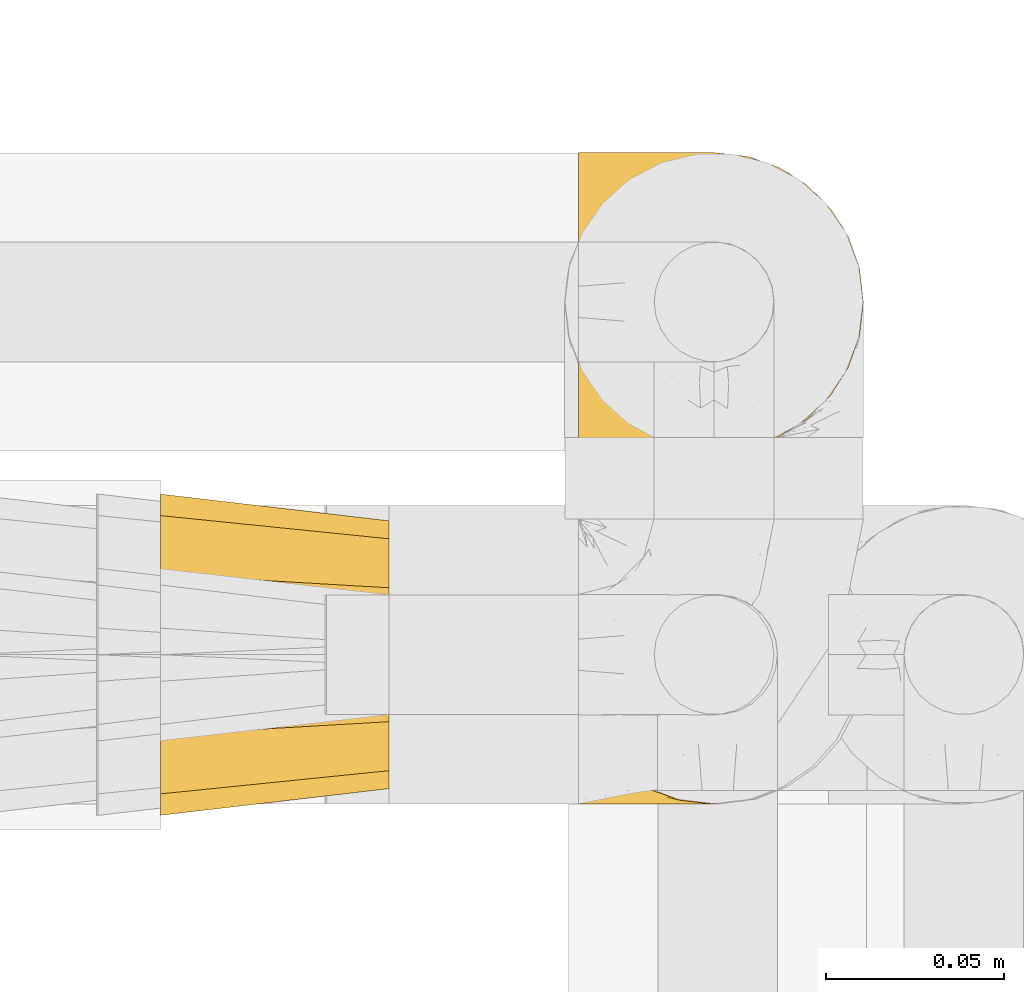
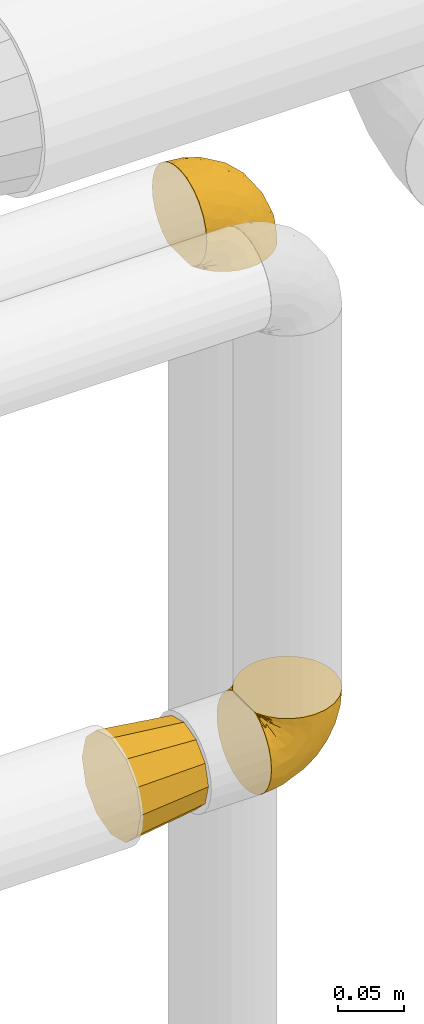
# One storey, part 455 of 827: 3 coverings.
"""IFC2X3 building model written with IfcOpenShell, lengths in millimetres."""

from ifc_helpers import new_model, entity, si_unit, converted_unit, derived_unit, direction, frame, origin, place, context, subcontext, project, spatial, faceted_brep, element, save


model = new_model("IFC2X3")

# Units and contexts
model_context = context("Model", 3, precision=0.01, world=origin(), true_north=direction((6.12303176911189e-17, 1.0)))
body_context = subcontext(model_context, "Body", "Model", "MODEL_VIEW")
ifc_project = project(units=[si_unit("LENGTHUNIT", "METRE", prefix="MILLI"), si_unit("AREAUNIT", "SQUARE_METRE"), si_unit("VOLUMEUNIT", "CUBIC_METRE"), converted_unit("PLANEANGLEUNIT", "DEGREE", entity("IfcRatioMeasure", 0.0174532925199433), si_unit("PLANEANGLEUNIT", "RADIAN"), dimensions=[0, 0, 0, 0, 0, 0, 0]), si_unit("MASSUNIT", "GRAM", prefix="KILO"), derived_unit("MASSDENSITYUNIT", [(si_unit("MASSUNIT", "GRAM", prefix="KILO"), 1), (si_unit("LENGTHUNIT", "METRE"), -3)]), derived_unit("MOMENTOFINERTIAUNIT", [(si_unit("LENGTHUNIT", "METRE"), 4)]), si_unit("TIMEUNIT", "SECOND"), si_unit("FREQUENCYUNIT", "HERTZ"), si_unit("THERMODYNAMICTEMPERATUREUNIT", "DEGREE_CELSIUS"), derived_unit("THERMALTRANSMITTANCEUNIT", [(si_unit("MASSUNIT", "GRAM", prefix="KILO"), 1), (si_unit("THERMODYNAMICTEMPERATUREUNIT", "KELVIN"), -1), (si_unit("TIMEUNIT", "SECOND"), -3)]), derived_unit("VOLUMETRICFLOWRATEUNIT", [(si_unit("LENGTHUNIT", "METRE"), 3), (si_unit("TIMEUNIT", "SECOND"), -1)]), derived_unit("MASSFLOWRATEUNIT", [(si_unit("MASSUNIT", "GRAM", prefix="KILO"), 1), (si_unit("TIMEUNIT", "SECOND"), -1)]), derived_unit("ROTATIONALFREQUENCYUNIT", [(si_unit("TIMEUNIT", "SECOND"), -1)]), si_unit("ELECTRICCURRENTUNIT", "AMPERE"), si_unit("ELECTRICVOLTAGEUNIT", "VOLT"), si_unit("POWERUNIT", "WATT"), si_unit("FORCEUNIT", "NEWTON", prefix="KILO"), si_unit("ILLUMINANCEUNIT", "LUX"), si_unit("LUMINOUSFLUXUNIT", "LUMEN"), si_unit("LUMINOUSINTENSITYUNIT", "CANDELA"), derived_unit("USERDEFINED", [(si_unit("MASSUNIT", "GRAM", prefix="KILO"), -1), (si_unit("LENGTHUNIT", "METRE"), -2), (si_unit("TIMEUNIT", "SECOND"), 3), (si_unit("LUMINOUSFLUXUNIT", "LUMEN"), 1)]), derived_unit("LINEARVELOCITYUNIT", [(si_unit("LENGTHUNIT", "METRE"), 1), (si_unit("TIMEUNIT", "SECOND"), -1)]), si_unit("PRESSUREUNIT", "PASCAL"), derived_unit("USERDEFINED", [(si_unit("LENGTHUNIT", "METRE"), -2), (si_unit("MASSUNIT", "GRAM", prefix="KILO"), 1), (si_unit("TIMEUNIT", "SECOND"), -2)]), derived_unit("LINEARFORCEUNIT", [(si_unit("MASSUNIT", "GRAM", prefix="KILO"), 1), (si_unit("LENGTHUNIT", "METRE"), 1), (si_unit("TIMEUNIT", "SECOND"), -2), (si_unit("LENGTHUNIT", "METRE"), -1)]), derived_unit("PLANARFORCEUNIT", [(si_unit("MASSUNIT", "GRAM", prefix="KILO"), 1), (si_unit("LENGTHUNIT", "METRE"), 1), (si_unit("TIMEUNIT", "SECOND"), -2), (si_unit("LENGTHUNIT", "METRE"), -2)])], contexts=[model_context])

# Site, building, storey
site_placement = place(None, origin())
site = spatial("IfcSite", under=ifc_project, at=site_placement, CompositionType="ELEMENT")
building_placement = place(site_placement, origin())
building = spatial("IfcBuilding", under=site, at=building_placement, CompositionType="ELEMENT")
storey_placement = place(building_placement, frame((0.0, 0.0, 28200.0)))
storey = spatial("IfcBuildingStorey", under=building, at=storey_placement, Name="08", CompositionType="ELEMENT", Elevation=28200.0)

# Coverings
covering_1_placement = place(storey_placement, frame((56523.63, 17456.55, 2524.05)))
element("IfcCovering", 1, at=covering_1_placement, inside=storey, Name=":ADSK_", ObjectType=":ADSK_", PredefinedType="INSULATION", context=body_context, shape_type="Brep", body=[
    faceted_brep([(1.6, 81.15, 25.28), (1.6, 76.16, 17.35), (1.6, 69.53, 10.72), (1.6, 61.6, 5.74), (1.6, 52.75, 2.64), (1.6, 43.45, 1.6), (1.6, 34.13, 2.65), (1.6, 25.28, 5.74), (1.6, 17.35, 10.73), (1.6, 10.72, 17.36), (1.6, 5.74, 25.29), (1.6, 2.64, 34.14), (1.6, 1.6, 43.45), (1.6, 2.66, 52.82), (1.6, 5.79, 61.71), (1.6, 10.83, 69.67), (1.6, 17.53, 76.31), (1.6, 25.53, 81.27), (1.6, 26.45, 81.27), (1.6, 27.37, 81.27), (1.6, 28.17, 81.27), (1.6, 29.49, 81.27), (1.6, 30.81, 81.27), (1.6, 32.13, 81.27), (1.6, 33.45, 81.27), (1.6, 34.78, 81.27), (1.6, 36.1, 81.27), (1.6, 37.42, 81.27), (1.6, 38.74, 81.27), (1.6, 40.06, 81.27), (1.6, 41.38, 81.27), (1.6, 42.7, 81.27), (1.6, 44.02, 81.27), (1.6, 45.34, 81.27), (1.6, 46.66, 81.27), (1.6, 47.58, 81.27), (1.6, 48.5, 81.27), (1.6, 49.41, 81.27), (1.6, 50.33, 81.27), (1.6, 51.25, 81.27), (1.6, 52.17, 81.27), (1.6, 53.09, 81.27), (1.6, 54.01, 81.27), (1.6, 54.93, 81.27), (1.6, 55.85, 81.27), (1.6, 56.76, 81.27), (1.6, 57.68, 81.27), (1.6, 58.6, 81.27), (1.6, 59.52, 81.27), (1.6, 60.44, 81.27), (1.6, 61.36, 81.27), (1.6, 69.37, 76.3), (1.6, 76.07, 69.66), (1.6, 81.11, 61.69), (1.6, 84.24, 52.8), (1.6, 85.3, 43.45), (1.6, 84.24, 34.13), (6.74, 17.52, 81.45), (13.37, 10.83, 81.45), (21.34, 5.79, 81.45), (30.23, 2.66, 81.45), (39.6, 1.6, 81.45), (50.43, 3.02, 81.45), (60.52, 7.2, 81.45), (69.19, 13.85, 81.45), (75.84, 22.52, 81.45), (80.02, 32.61, 81.45), (81.45, 43.45, 81.45), (80.02, 54.28, 81.45), (75.84, 64.37, 81.45), (69.19, 73.04, 81.45), (60.52, 79.69, 81.45), (50.43, 83.87, 81.45), (39.6, 85.3, 81.45), (30.23, 84.23, 81.45), (21.34, 81.1, 81.45), (13.37, 76.06, 81.45), (6.74, 69.37, 81.45), (1.77, 61.36, 81.45), (1.77, 60.44, 81.45), (1.77, 59.12, 81.45), (1.77, 58.0, 81.45), (1.77, 56.88, 81.45), (1.77, 55.76, 81.45), (1.77, 54.64, 81.45), (1.77, 53.52, 81.45), (1.77, 52.4, 81.45), (1.77, 51.28, 81.45), (1.77, 50.16, 81.45), (1.77, 49.04, 81.45), (1.77, 47.92, 81.45), (1.77, 46.8, 81.45), (1.77, 45.68, 81.45), (1.77, 44.56, 81.45), (1.77, 43.45, 81.45), (1.77, 42.12, 81.45), (1.77, 40.8, 81.45), (1.77, 39.48, 81.45), (1.77, 38.16, 81.45), (1.77, 36.84, 81.45), (1.77, 35.52, 81.45), (1.77, 34.2, 81.45), (1.77, 32.88, 81.45), (1.77, 31.96, 81.45), (1.77, 31.05, 81.45), (1.77, 30.13, 81.45), (1.77, 29.21, 81.45), (1.77, 28.29, 81.45), (1.77, 27.37, 81.45), (1.77, 26.45, 81.45), (1.77, 25.53, 81.45), (1.73, 54.08, 81.33), (1.72, 55.16, 81.32), (1.73, 36.18, 81.33), (1.72, 35.13, 81.32), (1.73, 44.01, 81.33), (1.73, 45.08, 81.32), (1.72, 61.36, 81.32), (1.72, 59.98, 81.32), (1.72, 46.18, 81.32), (1.72, 26.74, 81.32), (1.72, 47.36, 81.32), (1.73, 29.67, 81.32), (1.74, 28.72, 81.34), (1.72, 39.77, 81.32), (1.71, 52.96, 81.31), (1.73, 51.84, 81.33), (1.71, 40.8, 81.31), (1.72, 41.87, 81.32), (1.73, 42.94, 81.33), (1.72, 27.77, 81.32), (1.73, 48.4, 81.33), (1.72, 37.21, 81.32), (1.73, 33.54, 81.33), (1.72, 32.49, 81.32), (1.72, 30.69, 81.32), (1.72, 50.69, 81.32), (1.71, 49.6, 81.31), (1.72, 56.32, 81.32), (1.73, 57.44, 81.33), (1.71, 58.88, 81.31), (1.72, 25.53, 81.32), (1.68, 61.36, 81.3), (1.64, 61.36, 81.29), (1.64, 25.53, 81.29), (1.68, 25.53, 81.3), (1.75, 61.36, 81.4), (1.74, 61.36, 81.36), (1.74, 25.53, 81.36), (1.75, 25.53, 81.4), (1.7, 31.59, 81.3), (1.73, 38.71, 81.33), (24.54, 3.97, 74.06), (11.1, 1.6, 45.99), (8.47, 3.97, 58.35), (9.11, 8.09, 67.76), (4.86, 8.09, 66.18), (5.0, 16.43, 76.46), (6.81, 15.73, 77.33), (37.05, 1.6, 71.95), (9.03, 10.79, 72.25), (9.47, 13.99, 78.91), (16.39, 8.08, 76.42), (3.95, 14.0, 73.52), (9.9, 12.83, 76.9), (22.7, 3.18, 65.25), (34.5, 1.6, 62.45), (37.68, 1.6, 74.31), (15.82, 3.28, 59.38), (20.6, 1.6, 48.54), (14.37, 6.28, 67.72), (27.55, 1.6, 55.49), (5.2, 19.06, 79.73), (14.88, 8.08, 73.23), (8.73, 1.6, 45.36), (44.27, 32.11, 15.81), (20.94, 29.62, 6.4), (32.15, 43.45, 7.67), (46.13, 2.45, 68.46), (42.67, 2.5, 59.33), (55.18, 9.73, 48.7), (67.27, 17.97, 53.94), (62.91, 10.24, 65.02), (51.5, 4.78, 60.77), (54.79, 4.78, 72.07), (25.78, 8.01, 26.25), (13.05, 8.01, 22.29), (18.46, 13.85, 16.0), (32.4, 2.42, 46.93), (31.07, 21.17, 14.19), (77.32, 35.73, 58.46), (75.62, 27.43, 61.51), (16.9, 43.45, 4.64), (71.69, 17.97, 68.93), (61.4, 35.71, 29.62), (54.47, 29.47, 24.85), (27.66, 3.41, 38.55), (14.53, 3.94, 31.27), (15.56, 21.17, 9.35), (42.26, 7.92, 37.15), (41.51, 4.25, 47.07), (36.93, 11.75, 26.49), (42.72, 18.31, 23.01), (44.68, 24.94, 19.4), (71.2, 28.78, 48.06), (70.48, 35.82, 42.46), (75.37, 43.45, 50.89), (63.65, 28.38, 35.78), (58.06, 43.45, 24.98), (45.11, 43.45, 16.33), (78.4, 43.45, 66.14), (54.95, 21.21, 30.96), (59.31, 16.48, 41.83), (49.01, 13.85, 33.28), (66.71, 43.45, 37.94), (53.75, 82.11, 67.39), (77.27, 51.41, 58.47), (61.6, 57.45, 32.5), (44.24, 54.78, 15.79), (18.46, 73.03, 15.99), (15.55, 65.7, 9.34), (60.14, 76.65, 56.91), (70.5, 68.92, 63.5), (63.0, 68.01, 44.08), (25.78, 78.88, 26.24), (13.05, 78.88, 22.27), (14.53, 82.94, 31.26), (48.5, 64.44, 23.95), (44.23, 84.49, 63.79), (34.5, 85.3, 62.45), (37.05, 85.3, 71.95), (8.73, 85.3, 45.36), (77.68, 57.84, 67.83), (64.08, 76.65, 70.28), (70.25, 51.19, 42.11), (20.93, 57.26, 6.39), (49.9, 78.14, 43.54), (49.6, 82.35, 58.03), (31.06, 65.7, 14.18), (39.62, 84.61, 56.34), (34.42, 84.36, 48.09), (20.6, 85.3, 48.54), (27.55, 85.3, 55.49), (33.36, 73.03, 21.78), (27.68, 83.48, 38.54), (11.1, 85.3, 45.99), (46.67, 84.54, 72.79), (49.0, 73.03, 33.26), (38.94, 79.54, 35.53), (73.05, 59.46, 53.66), (56.63, 73.5, 43.03), (43.85, 82.57, 49.68), (24.54, 82.92, 74.06), (15.82, 83.62, 59.37), (8.47, 82.92, 58.34), (9.12, 78.81, 67.75), (9.47, 72.9, 78.91), (9.91, 74.06, 76.9), (16.85, 78.81, 78.08), (14.88, 78.81, 73.23), (5.2, 67.83, 79.73), (6.81, 71.15, 77.34), (3.96, 72.91, 73.51), (5.0, 70.47, 76.45), (5.86, 78.81, 66.41), (14.38, 80.62, 67.7), (9.04, 76.11, 72.24), (22.7, 83.71, 65.25)], [[[0, 1, 2, 3, 4, 5, 6, 7, 8, 9, 10, 11, 12, 13, 14, 15, 16, 17, 18, 19, 20, 21, 22, 23, 24, 25, 26, 27, 28, 29, 30, 31, 32, 33, 34, 35, 36, 37, 38, 39, 40, 41, 42, 43, 44, 45, 46, 47, 48, 49, 50, 51, 52, 53, 54, 55, 56]], [[57, 58, 59, 60, 61, 62, 63, 64, 65, 66, 67, 68, 69, 70, 71, 72, 73, 74, 75, 76, 77, 78, 79, 80, 81, 82, 83, 84, 85, 86, 87, 88, 89, 90, 91, 92, 93, 94, 95, 96, 97, 98, 99, 100, 101, 102, 103, 104, 105, 106, 107, 108, 109, 110]], [[111, 84, 112]], [[113, 26, 114]], [[114, 101, 100]], [[115, 93, 116]], [[79, 117, 118]], [[33, 116, 119]], [[117, 49, 118]], [[19, 18, 120]], [[119, 121, 34]], [[122, 21, 123]], [[97, 96, 124]], [[86, 125, 126]], [[116, 92, 119]], [[127, 96, 128]], [[32, 129, 115]], [[19, 120, 130]], [[121, 90, 131]], [[94, 115, 129]], [[115, 116, 32]], [[118, 49, 48]], [[113, 99, 132]], [[133, 114, 25]], [[24, 134, 133]], [[135, 22, 122]], [[136, 137, 88]], [[84, 83, 112]], [[138, 82, 139]], [[130, 20, 19]], [[118, 48, 140]], [[81, 140, 139]], [[123, 21, 20]], [[141, 120, 18]], [[139, 82, 81]], [[130, 107, 123]], [[49, 117, 142, 143, 50]], [[18, 17, 144, 145, 141]], [[79, 78, 146, 147, 117]], [[109, 141, 148, 149, 110]], [[102, 133, 134]], [[105, 135, 122]], [[118, 80, 79]], [[80, 118, 140]], [[120, 109, 108]], [[47, 46, 140, 48]], [[81, 80, 140]], [[44, 112, 138]], [[93, 115, 94]], [[46, 139, 140]], [[46, 45, 139]], [[139, 45, 138]], [[138, 112, 83]], [[85, 84, 111]], [[112, 43, 111]], [[83, 82, 138]], [[106, 122, 123]], [[105, 122, 106]], [[21, 122, 22]], [[124, 29, 28]], [[33, 32, 116]], [[128, 129, 31]], [[32, 31, 129]], [[34, 33, 119]], [[116, 93, 92]], [[129, 95, 94]], [[95, 129, 128]], [[41, 40, 125, 42]], [[119, 91, 121]], [[36, 35, 131, 37]], [[137, 131, 89]], [[121, 131, 35]], [[90, 121, 91]], [[119, 92, 91]], [[136, 126, 39]], [[125, 86, 85]], [[42, 125, 111]], [[85, 111, 125]], [[150, 23, 22]], [[130, 108, 107]], [[130, 123, 20]], [[107, 106, 123]], [[137, 37, 131]], [[136, 38, 137]], [[89, 88, 137]], [[131, 90, 89]], [[124, 151, 97]], [[40, 39, 126]], [[87, 126, 136]], [[86, 126, 87]], [[136, 88, 87]], [[40, 126, 125]], [[39, 38, 136]], [[95, 128, 96]], [[30, 128, 31]], [[29, 124, 127]], [[127, 128, 30]], [[151, 124, 28]], [[127, 30, 29]], [[127, 124, 96]], [[151, 98, 97]], [[45, 44, 138]], [[26, 113, 132]], [[113, 100, 99]], [[132, 151, 27]], [[27, 26, 132]], [[26, 25, 114]], [[100, 113, 114]], [[101, 133, 102]], [[133, 101, 114]], [[28, 27, 151]], [[132, 99, 98]], [[23, 134, 24]], [[25, 24, 133]], [[134, 23, 150]], [[135, 104, 150]], [[150, 104, 103]], [[103, 102, 134]], [[130, 120, 108]], [[109, 120, 141]], [[42, 111, 43]], [[112, 44, 43]], [[104, 135, 105]], [[134, 150, 103]], [[135, 150, 22]], [[35, 34, 121]], [[137, 38, 37]], [[98, 151, 132]], [[59, 152, 60]], [[13, 153, 154]], [[155, 156, 154]], [[157, 158, 141]], [[159, 60, 152]], [[160, 157, 155]], [[161, 162, 58]], [[58, 162, 59]], [[144, 16, 163]], [[58, 57, 161]], [[162, 161, 164]], [[157, 163, 155]], [[163, 16, 15]], [[57, 149, 161]], [[152, 165, 166]], [[157, 144, 163]], [[60, 159, 167, 61]], [[156, 14, 154]], [[163, 156, 155]], [[155, 154, 168]], [[168, 154, 169]], [[155, 170, 160]], [[57, 110, 149]], [[144, 17, 16]], [[156, 15, 14]], [[171, 165, 168]], [[158, 164, 172]], [[14, 13, 154]], [[157, 145, 144]], [[173, 164, 158]], [[173, 160, 170]], [[171, 166, 165]], [[168, 165, 170]], [[168, 169, 171]], [[152, 173, 165]], [[170, 155, 168]], [[165, 173, 170]], [[160, 173, 158]], [[172, 149, 148]], [[148, 141, 158]], [[158, 157, 160]], [[152, 166, 159]], [[173, 152, 162]], [[59, 162, 152]], [[13, 12, 174, 153]], [[153, 169, 154]], [[15, 156, 163]], [[157, 141, 145]], [[162, 164, 173]], [[172, 164, 161]], [[149, 172, 161]], [[158, 172, 148]], [[175, 176, 177]], [[178, 166, 179]], [[180, 181, 182]], [[183, 184, 178]], [[185, 186, 187]], [[171, 188, 179]], [[174, 12, 11]], [[189, 176, 175]], [[190, 66, 191]], [[176, 6, 192]], [[193, 65, 64]], [[63, 184, 182]], [[63, 182, 64]], [[65, 193, 191]], [[184, 63, 62]], [[175, 194, 195]], [[196, 169, 197]], [[174, 11, 197]], [[8, 7, 198]], [[187, 9, 8]], [[197, 169, 153, 174]], [[197, 11, 10]], [[186, 197, 10]], [[199, 180, 200]], [[197, 185, 196]], [[201, 189, 202]], [[201, 187, 189]], [[195, 203, 175]], [[191, 204, 190]], [[176, 7, 6]], [[177, 176, 192]], [[189, 198, 176]], [[65, 191, 66]], [[198, 187, 8]], [[205, 206, 190]], [[9, 186, 10]], [[181, 207, 204]], [[208, 175, 177, 209]], [[66, 190, 210]], [[211, 212, 213]], [[190, 204, 205]], [[180, 182, 183]], [[193, 182, 181]], [[62, 61, 167]], [[196, 185, 199]], [[196, 200, 188]], [[6, 5, 192]], [[176, 198, 7]], [[187, 198, 189]], [[187, 186, 9]], [[197, 186, 185]], [[200, 180, 183]], [[180, 213, 212]], [[179, 183, 178]], [[185, 201, 199]], [[210, 190, 206]], [[210, 67, 66]], [[205, 204, 207]], [[194, 205, 207]], [[194, 214, 205]], [[195, 194, 207]], [[208, 194, 175]], [[207, 211, 195]], [[202, 203, 211]], [[212, 207, 181]], [[202, 211, 213]], [[201, 202, 213]], [[189, 175, 203]], [[199, 201, 213]], [[187, 201, 185]], [[180, 199, 213]], [[196, 199, 200]], [[211, 203, 195]], [[189, 203, 202]], [[207, 212, 211]], [[180, 212, 181]], [[214, 194, 208]], [[214, 206, 205]], [[196, 188, 169]], [[181, 204, 191]], [[182, 193, 64]], [[191, 193, 181]], [[178, 62, 167]], [[182, 184, 183]], [[62, 178, 184]], [[178, 167, 159, 166]], [[171, 179, 166]], [[200, 183, 179]], [[179, 188, 200]], [[169, 188, 171]], [[71, 215, 72]], [[206, 216, 210]], [[217, 208, 218]], [[216, 68, 210]], [[219, 220, 2]], [[221, 222, 223]], [[224, 225, 226]], [[227, 223, 217]], [[228, 229, 230]], [[56, 231, 226]], [[232, 222, 69]], [[56, 55, 231]], [[70, 233, 71]], [[71, 233, 215]], [[0, 56, 226]], [[208, 217, 234]], [[218, 177, 235]], [[221, 236, 237]], [[238, 220, 219]], [[1, 219, 2]], [[68, 216, 232]], [[235, 3, 220]], [[235, 192, 4]], [[1, 0, 225]], [[228, 239, 229]], [[240, 241, 242]], [[243, 238, 219]], [[224, 226, 244]], [[226, 241, 244]], [[3, 235, 4]], [[69, 222, 70]], [[225, 219, 1]], [[218, 235, 238]], [[243, 219, 224]], [[218, 227, 217]], [[3, 2, 220]], [[218, 208, 209, 177]], [[226, 231, 245, 241]], [[215, 228, 246]], [[247, 248, 236]], [[248, 224, 244]], [[223, 222, 249]], [[233, 222, 221]], [[242, 239, 240]], [[248, 247, 243]], [[217, 223, 249]], [[250, 247, 236]], [[216, 234, 249]], [[218, 238, 227]], [[192, 235, 177]], [[192, 5, 4]], [[72, 246, 73]], [[235, 220, 238]], [[226, 225, 0]], [[219, 225, 224]], [[240, 248, 244]], [[239, 242, 229]], [[236, 248, 251]], [[68, 67, 210]], [[234, 216, 206]], [[216, 249, 232]], [[234, 206, 214, 208]], [[249, 234, 217]], [[222, 232, 249]], [[69, 68, 232]], [[246, 228, 230]], [[237, 228, 215]], [[243, 227, 238]], [[223, 227, 247]], [[73, 246, 230]], [[215, 246, 72]], [[248, 243, 224]], [[227, 243, 247]], [[237, 236, 251]], [[250, 221, 223]], [[222, 233, 70]], [[215, 233, 221]], [[221, 237, 215]], [[239, 237, 251]], [[237, 239, 228]], [[239, 251, 240]], [[248, 240, 251]], [[241, 240, 244]], [[221, 250, 236]], [[223, 247, 250]], [[74, 230, 252]], [[253, 254, 255]], [[146, 77, 256]], [[257, 258, 259]], [[260, 256, 257]], [[260, 261, 147]], [[75, 74, 252]], [[51, 143, 262]], [[263, 143, 142, 117]], [[256, 77, 76]], [[252, 258, 75]], [[253, 241, 254]], [[254, 245, 54]], [[258, 256, 76]], [[53, 52, 264]], [[255, 265, 253]], [[254, 264, 255]], [[255, 264, 262]], [[75, 258, 76]], [[265, 255, 266]], [[255, 262, 263]], [[51, 50, 143]], [[54, 245, 231, 55]], [[51, 262, 52]], [[253, 267, 242]], [[254, 54, 53]], [[266, 259, 265]], [[146, 78, 77]], [[263, 117, 261]], [[146, 256, 260]], [[257, 259, 261]], [[267, 253, 265]], [[229, 267, 252]], [[242, 267, 229]], [[242, 241, 253]], [[252, 267, 259]], [[255, 263, 266]], [[259, 267, 265]], [[261, 117, 147]], [[263, 261, 266]], [[259, 266, 261]], [[230, 74, 73]], [[230, 229, 252]], [[259, 258, 252]], [[254, 241, 245]], [[53, 264, 254]], [[52, 262, 264]], [[143, 263, 262]], [[258, 257, 256]], [[261, 260, 257]], [[146, 260, 147]]]),
])
covering_2_placement = place(storey_placement, frame((56408.19, 17453.4, 2520.9)))
element("IfcCovering", 2, at=covering_2_placement, inside=storey, Name=":ADSK_", ObjectType=":ADSK_", PredefinedType="INSULATION", context=body_context, shape_type="Brep", body=[
    faceted_brep([(0.0, 69.1, 7.62), (0.0, 59.65, 5.09), (0.0, 46.6, 1.6), (0.0, 33.54, 5.09), (0.0, 24.1, 7.62), (0.0, 15.86, 15.86), (0.0, 7.62, 24.1), (0.0, 5.09, 33.54), (0.0, 1.6, 46.6), (0.0, 5.09, 59.65), (0.0, 7.62, 69.1), (0.0, 15.86, 77.33), (0.0, 24.1, 85.57), (0.0, 33.54, 88.1), (0.0, 46.6, 91.6), (0.0, 59.65, 88.1), (0.0, 69.1, 85.57), (0.0, 77.33, 77.33), (0.0, 85.57, 69.1), (0.0, 88.1, 59.65), (0.0, 91.6, 46.6), (0.0, 88.1, 33.54), (0.0, 85.57, 24.1), (0.0, 77.33, 15.86), (64.0, 27.85, 79.07), (64.0, 20.98, 72.21), (64.0, 14.12, 65.35), (64.0, 11.61, 55.97), (64.0, 9.1, 46.6), (64.0, 11.61, 37.22), (64.0, 14.12, 27.85), (64.0, 20.98, 20.98), (64.0, 27.85, 14.12), (64.0, 37.22, 11.61), (64.0, 46.6, 9.1), (64.0, 55.97, 11.61), (64.0, 65.35, 14.12), (64.0, 72.21, 20.98), (64.0, 79.07, 27.85), (64.0, 81.58, 37.22), (64.0, 84.1, 46.6), (64.0, 81.58, 55.97), (64.0, 79.07, 65.35), (64.0, 72.21, 72.21), (64.0, 65.35, 79.07), (64.0, 55.97, 81.58), (64.0, 46.6, 84.1), (64.0, 37.22, 81.58)], [[[0, 1, 2, 3, 4, 5, 6, 7, 8, 9, 10, 11, 12, 13, 14, 15, 16, 17, 18, 19, 20, 21, 22, 23]], [[24, 25, 26, 27, 28, 29, 30, 31, 32, 33, 34, 35, 36, 37, 38, 39, 40, 41, 42, 43, 44, 45, 46, 47]], [[38, 22, 21, 20, 40, 39]], [[23, 22, 38, 37, 36, 0]], [[35, 34, 2, 1, 0, 36]], [[32, 4, 3, 2, 34, 33]], [[5, 4, 32, 31, 30, 6]], [[29, 28, 8, 7, 6, 30]], [[26, 10, 9, 8, 28, 27]], [[11, 10, 26, 25, 24, 12]], [[47, 46, 14, 13, 12, 24]], [[44, 16, 15, 14, 46, 45]], [[17, 16, 44, 43, 42, 18]], [[41, 40, 20, 19, 18, 42]]]),
])
covering_3_placement = place(storey_placement, frame((56523.63, 17555.37, 2960.49)))
element("IfcCovering", 3, at=covering_3_placement, inside=storey, Name=":ADSK_", ObjectType=":ADSK_", PredefinedType="INSULATION", context=body_context, shape_type="Brep", body=[
    faceted_brep([(57.76, 81.15, 1.6), (65.69, 76.16, 1.6), (72.32, 69.53, 1.6), (77.3, 61.6, 1.6), (80.4, 52.75, 1.6), (81.45, 43.45, 1.6), (80.39, 34.13, 1.6), (77.3, 25.28, 1.6), (72.31, 17.35, 1.6), (65.68, 10.72, 1.6), (57.75, 5.74, 1.6), (48.9, 2.64, 1.6), (39.6, 1.6, 1.6), (30.22, 2.66, 1.6), (21.33, 5.79, 1.6), (13.37, 10.83, 1.6), (6.73, 17.53, 1.6), (1.77, 25.53, 1.6), (1.77, 26.45, 1.6), (1.77, 27.37, 1.6), (1.77, 28.17, 1.6), (1.77, 29.49, 1.6), (1.77, 30.81, 1.6), (1.77, 32.13, 1.6), (1.77, 33.45, 1.6), (1.77, 34.78, 1.6), (1.77, 36.1, 1.6), (1.77, 37.42, 1.6), (1.77, 38.74, 1.6), (1.77, 40.06, 1.6), (1.77, 41.38, 1.6), (1.77, 42.7, 1.6), (1.77, 44.02, 1.6), (1.77, 45.34, 1.6), (1.77, 46.66, 1.6), (1.77, 47.58, 1.6), (1.77, 48.5, 1.6), (1.77, 49.41, 1.6), (1.77, 50.33, 1.6), (1.77, 51.25, 1.6), (1.77, 52.17, 1.6), (1.77, 53.09, 1.6), (1.77, 54.01, 1.6), (1.77, 54.93, 1.6), (1.77, 55.85, 1.6), (1.77, 56.76, 1.6), (1.77, 57.68, 1.6), (1.77, 58.6, 1.6), (1.77, 59.52, 1.6), (1.77, 60.44, 1.6), (1.77, 61.36, 1.6), (6.74, 69.37, 1.6), (13.38, 76.07, 1.6), (21.35, 81.11, 1.6), (30.24, 84.24, 1.6), (39.6, 85.3, 1.6), (48.91, 84.24, 1.6), (1.6, 17.52, 6.74), (1.6, 10.83, 13.37), (1.6, 5.79, 21.34), (1.6, 2.66, 30.23), (1.6, 1.6, 39.6), (1.6, 3.02, 50.43), (1.6, 7.2, 60.52), (1.6, 13.85, 69.19), (1.6, 22.52, 75.84), (1.6, 32.61, 80.02), (1.6, 43.45, 81.45), (1.6, 54.28, 80.02), (1.6, 64.37, 75.84), (1.6, 73.04, 69.19), (1.6, 79.69, 60.52), (1.6, 83.87, 50.43), (1.6, 85.3, 39.6), (1.6, 84.23, 30.23), (1.6, 81.1, 21.34), (1.6, 76.06, 13.37), (1.6, 69.37, 6.74), (1.6, 61.36, 1.77), (1.6, 60.44, 1.77), (1.6, 59.12, 1.77), (1.6, 58.0, 1.77), (1.6, 56.88, 1.77), (1.6, 55.76, 1.77), (1.6, 54.64, 1.77), (1.6, 53.52, 1.77), (1.6, 52.4, 1.77), (1.6, 51.28, 1.77), (1.6, 50.16, 1.77), (1.6, 49.04, 1.77), (1.6, 47.92, 1.77), (1.6, 46.8, 1.77), (1.6, 45.68, 1.77), (1.6, 44.56, 1.77), (1.6, 43.45, 1.77), (1.6, 42.12, 1.77), (1.6, 40.8, 1.77), (1.6, 39.48, 1.77), (1.6, 38.16, 1.77), (1.6, 36.84, 1.77), (1.6, 35.52, 1.77), (1.6, 34.2, 1.77), (1.6, 32.88, 1.77), (1.6, 31.96, 1.77), (1.6, 31.05, 1.77), (1.6, 30.13, 1.77), (1.6, 29.21, 1.77), (1.6, 28.29, 1.77), (1.6, 27.37, 1.77), (1.6, 26.45, 1.77), (1.6, 25.53, 1.77), (1.71, 54.08, 1.73), (1.73, 55.16, 1.72), (1.71, 36.18, 1.73), (1.72, 35.13, 1.72), (1.71, 44.01, 1.73), (1.72, 45.08, 1.73), (1.72, 61.36, 1.72), (1.72, 59.98, 1.72), (1.72, 46.18, 1.72), (1.72, 26.74, 1.72), (1.72, 47.36, 1.72), (1.72, 29.67, 1.73), (1.7, 28.72, 1.74), (1.72, 39.77, 1.72), (1.73, 52.96, 1.71), (1.72, 51.84, 1.73), (1.73, 40.8, 1.71), (1.73, 41.87, 1.72), (1.72, 42.94, 1.73), (1.72, 27.77, 1.72), (1.71, 48.4, 1.73), (1.72, 37.21, 1.72), (1.71, 33.54, 1.73), (1.72, 32.49, 1.72), (1.72, 30.69, 1.72), (1.72, 50.69, 1.72), (1.73, 49.6, 1.71), (1.72, 56.32, 1.72), (1.71, 57.44, 1.73), (1.73, 58.88, 1.71), (1.72, 25.53, 1.72), (1.74, 61.36, 1.68), (1.75, 61.36, 1.64), (1.75, 25.53, 1.64), (1.74, 25.53, 1.68), (1.64, 61.36, 1.75), (1.68, 61.36, 1.74), (1.68, 25.53, 1.74), (1.64, 25.53, 1.75), (1.74, 31.59, 1.7), (1.71, 38.71, 1.73), (8.98, 3.97, 24.54), (37.05, 1.6, 11.1), (24.69, 3.97, 8.47), (15.28, 8.09, 9.11), (16.86, 8.09, 4.86), (6.58, 16.43, 5.0), (5.71, 15.73, 6.81), (11.1, 1.6, 37.05), (10.79, 10.79, 9.03), (4.13, 13.99, 9.47), (6.62, 8.08, 16.39), (9.52, 14.0, 3.95), (6.14, 12.83, 9.9), (17.79, 3.18, 22.7), (20.6, 1.6, 34.5), (8.73, 1.6, 37.68), (23.66, 3.28, 15.82), (34.5, 1.6, 20.6), (15.32, 6.28, 14.37), (27.55, 1.6, 27.55), (3.31, 19.06, 5.2), (9.81, 8.08, 14.88), (37.68, 1.6, 8.73), (67.23, 32.11, 44.27), (76.64, 29.62, 20.94), (75.37, 43.45, 32.15), (14.58, 2.45, 46.13), (23.71, 2.5, 42.67), (34.34, 9.73, 55.18), (29.1, 17.97, 67.27), (18.02, 10.24, 62.91), (22.27, 4.78, 51.5), (10.97, 4.78, 54.79), (56.79, 8.01, 25.78), (60.76, 8.01, 13.05), (67.04, 13.85, 18.46), (36.11, 2.42, 32.4), (68.85, 21.17, 31.07), (24.58, 35.73, 77.32), (21.54, 27.43, 75.62), (78.4, 43.45, 16.9), (14.11, 17.97, 71.69), (53.42, 35.71, 61.4), (58.19, 29.47, 54.47), (44.49, 3.41, 27.66), (51.77, 3.94, 14.53), (73.69, 21.17, 15.56), (45.89, 7.92, 42.26), (35.97, 4.25, 41.51), (56.55, 11.75, 36.93), (60.03, 18.31, 42.72), (63.64, 24.94, 44.68), (34.98, 28.78, 71.2), (40.58, 35.82, 70.48), (32.15, 43.45, 75.37), (47.26, 28.38, 63.65), (58.06, 43.45, 58.06), (66.71, 43.45, 45.11), (16.9, 43.45, 78.4), (52.08, 21.21, 54.95), (41.21, 16.48, 59.31), (49.76, 13.85, 49.01), (45.11, 43.45, 66.71), (15.65, 82.11, 53.75), (24.57, 51.41, 77.27), (50.54, 57.45, 61.6), (67.25, 54.78, 44.24), (67.06, 73.03, 18.46), (73.7, 65.7, 15.55), (26.13, 76.65, 60.14), (19.54, 68.92, 70.5), (38.96, 68.01, 63.0), (56.8, 78.88, 25.78), (60.77, 78.88, 13.05), (51.78, 82.94, 14.53), (59.09, 64.44, 48.5), (19.25, 84.49, 44.23), (20.6, 85.3, 34.5), (11.1, 85.3, 37.05), (37.68, 85.3, 8.73), (15.21, 57.84, 77.68), (12.76, 76.65, 64.08), (40.93, 51.19, 70.25), (76.65, 57.26, 20.93), (39.5, 78.14, 49.9), (25.01, 82.35, 49.6), (68.86, 65.7, 31.06), (26.7, 84.61, 39.62), (34.95, 84.36, 34.42), (34.5, 85.3, 20.6), (27.55, 85.3, 27.55), (61.27, 73.03, 33.36), (44.5, 83.48, 27.68), (37.05, 85.3, 11.1), (10.25, 84.54, 46.67), (49.78, 73.03, 49.0), (47.51, 79.54, 38.94), (29.38, 59.46, 73.05), (40.01, 73.5, 56.63), (33.36, 82.57, 43.85), (8.98, 82.92, 24.54), (23.67, 83.62, 15.82), (24.71, 82.92, 8.47), (15.29, 78.81, 9.12), (4.13, 72.9, 9.47), (6.14, 74.06, 9.91), (4.96, 78.81, 16.85), (9.81, 78.81, 14.88), (3.31, 67.83, 5.2), (5.7, 71.15, 6.81), (9.53, 72.91, 3.96), (6.59, 70.47, 5.0), (16.63, 78.81, 5.86), (15.34, 80.62, 14.38), (10.8, 76.11, 9.04), (17.79, 83.71, 22.7)], [[[0, 1, 2, 3, 4, 5, 6, 7, 8, 9, 10, 11, 12, 13, 14, 15, 16, 17, 18, 19, 20, 21, 22, 23, 24, 25, 26, 27, 28, 29, 30, 31, 32, 33, 34, 35, 36, 37, 38, 39, 40, 41, 42, 43, 44, 45, 46, 47, 48, 49, 50, 51, 52, 53, 54, 55, 56]], [[57, 58, 59, 60, 61, 62, 63, 64, 65, 66, 67, 68, 69, 70, 71, 72, 73, 74, 75, 76, 77, 78, 79, 80, 81, 82, 83, 84, 85, 86, 87, 88, 89, 90, 91, 92, 93, 94, 95, 96, 97, 98, 99, 100, 101, 102, 103, 104, 105, 106, 107, 108, 109, 110]], [[111, 84, 112]], [[113, 26, 114]], [[114, 101, 100]], [[115, 93, 116]], [[79, 117, 118]], [[33, 116, 119]], [[117, 49, 118]], [[19, 18, 120]], [[119, 121, 34]], [[122, 21, 123]], [[97, 96, 124]], [[86, 125, 126]], [[116, 92, 119]], [[127, 96, 128]], [[32, 129, 115]], [[19, 120, 130]], [[121, 90, 131]], [[94, 115, 129]], [[115, 116, 32]], [[118, 49, 48]], [[113, 99, 132]], [[133, 114, 25]], [[24, 134, 133]], [[135, 22, 122]], [[136, 137, 88]], [[84, 83, 112]], [[138, 82, 139]], [[130, 20, 19]], [[118, 48, 140]], [[81, 140, 139]], [[123, 21, 20]], [[141, 120, 18]], [[139, 82, 81]], [[130, 107, 123]], [[49, 117, 142, 143, 50]], [[18, 17, 144, 145, 141]], [[79, 78, 146, 147, 117]], [[109, 141, 148, 149, 110]], [[102, 133, 134]], [[105, 135, 122]], [[118, 80, 79]], [[80, 118, 140]], [[120, 109, 108]], [[47, 46, 140, 48]], [[81, 80, 140]], [[44, 112, 138]], [[93, 115, 94]], [[46, 139, 140]], [[46, 45, 139]], [[139, 45, 138]], [[138, 112, 83]], [[85, 84, 111]], [[112, 43, 111]], [[83, 82, 138]], [[106, 122, 123]], [[105, 122, 106]], [[21, 122, 22]], [[124, 29, 28]], [[33, 32, 116]], [[128, 129, 31]], [[32, 31, 129]], [[34, 33, 119]], [[116, 93, 92]], [[129, 95, 94]], [[95, 129, 128]], [[41, 40, 125, 42]], [[119, 91, 121]], [[36, 35, 131, 37]], [[137, 131, 89]], [[121, 131, 35]], [[90, 121, 91]], [[119, 92, 91]], [[136, 126, 39]], [[125, 86, 85]], [[42, 125, 111]], [[85, 111, 125]], [[150, 23, 22]], [[130, 108, 107]], [[130, 123, 20]], [[107, 106, 123]], [[137, 37, 131]], [[136, 38, 137]], [[89, 88, 137]], [[131, 90, 89]], [[124, 151, 97]], [[40, 39, 126]], [[87, 126, 136]], [[86, 126, 87]], [[136, 88, 87]], [[40, 126, 125]], [[39, 38, 136]], [[95, 128, 96]], [[30, 128, 31]], [[29, 124, 127]], [[127, 128, 30]], [[151, 124, 28]], [[127, 30, 29]], [[127, 124, 96]], [[151, 98, 97]], [[45, 44, 138]], [[26, 113, 132]], [[113, 100, 99]], [[132, 151, 27]], [[27, 26, 132]], [[26, 25, 114]], [[100, 113, 114]], [[101, 133, 102]], [[133, 101, 114]], [[28, 27, 151]], [[132, 99, 98]], [[23, 134, 24]], [[25, 24, 133]], [[134, 23, 150]], [[135, 104, 150]], [[150, 104, 103]], [[103, 102, 134]], [[130, 120, 108]], [[109, 120, 141]], [[42, 111, 43]], [[112, 44, 43]], [[104, 135, 105]], [[134, 150, 103]], [[135, 150, 22]], [[35, 34, 121]], [[137, 38, 37]], [[98, 151, 132]], [[59, 152, 60]], [[13, 153, 154]], [[155, 156, 154]], [[157, 158, 141]], [[159, 60, 152]], [[160, 157, 155]], [[161, 162, 58]], [[58, 162, 59]], [[144, 16, 163]], [[58, 57, 161]], [[162, 161, 164]], [[157, 163, 155]], [[163, 16, 15]], [[57, 149, 161]], [[152, 165, 166]], [[157, 144, 163]], [[60, 159, 167, 61]], [[156, 14, 154]], [[163, 156, 155]], [[155, 154, 168]], [[168, 154, 169]], [[155, 170, 160]], [[57, 110, 149]], [[144, 17, 16]], [[156, 15, 14]], [[171, 165, 168]], [[158, 164, 172]], [[14, 13, 154]], [[157, 141, 145, 144]], [[173, 164, 158]], [[173, 160, 170]], [[171, 166, 165]], [[168, 165, 170]], [[168, 169, 171]], [[152, 173, 165]], [[170, 155, 168]], [[165, 173, 170]], [[160, 173, 158]], [[172, 149, 148]], [[148, 141, 158]], [[158, 157, 160]], [[152, 166, 159]], [[173, 152, 162]], [[59, 162, 152]], [[13, 12, 174, 153]], [[153, 169, 154]], [[15, 156, 163]], [[162, 164, 173]], [[172, 164, 161]], [[149, 172, 161]], [[158, 172, 148]], [[175, 176, 177]], [[178, 166, 179]], [[180, 181, 182]], [[183, 184, 178]], [[185, 186, 187]], [[171, 188, 179]], [[174, 12, 11]], [[189, 176, 175]], [[190, 66, 191]], [[176, 6, 192]], [[193, 65, 64]], [[63, 184, 182]], [[63, 182, 64]], [[65, 193, 191]], [[184, 63, 62]], [[175, 194, 195]], [[196, 169, 197]], [[174, 11, 197]], [[8, 7, 198]], [[187, 9, 8]], [[197, 169, 153, 174]], [[197, 11, 10]], [[186, 197, 10]], [[199, 180, 200]], [[197, 185, 196]], [[201, 189, 202]], [[201, 187, 189]], [[195, 203, 175]], [[191, 204, 190]], [[176, 7, 6]], [[177, 176, 192]], [[189, 198, 176]], [[65, 191, 66]], [[198, 187, 8]], [[205, 206, 190]], [[9, 186, 10]], [[181, 207, 204]], [[208, 175, 177, 209]], [[66, 190, 210]], [[211, 212, 213]], [[190, 204, 205]], [[180, 182, 183]], [[193, 182, 181]], [[62, 61, 167]], [[196, 185, 199]], [[196, 200, 188]], [[6, 5, 192]], [[176, 198, 7]], [[187, 198, 189]], [[187, 186, 9]], [[197, 186, 185]], [[200, 180, 183]], [[180, 213, 212]], [[179, 183, 178]], [[185, 201, 199]], [[210, 190, 206]], [[210, 67, 66]], [[205, 204, 207]], [[194, 205, 207]], [[194, 214, 205]], [[195, 194, 207]], [[208, 194, 175]], [[207, 211, 195]], [[202, 203, 211]], [[212, 207, 181]], [[202, 211, 213]], [[201, 202, 213]], [[189, 175, 203]], [[199, 201, 213]], [[187, 201, 185]], [[180, 199, 213]], [[196, 199, 200]], [[211, 203, 195]], [[189, 203, 202]], [[207, 212, 211]], [[180, 212, 181]], [[214, 194, 208]], [[214, 206, 205]], [[196, 188, 169]], [[181, 204, 191]], [[182, 193, 64]], [[191, 193, 181]], [[178, 62, 167]], [[182, 184, 183]], [[62, 178, 184]], [[178, 167, 159, 166]], [[171, 179, 166]], [[200, 183, 179]], [[179, 188, 200]], [[169, 188, 171]], [[71, 215, 72]], [[206, 216, 210]], [[217, 208, 218]], [[216, 68, 210]], [[219, 220, 2]], [[221, 222, 223]], [[224, 225, 226]], [[227, 223, 217]], [[228, 229, 230]], [[56, 231, 226]], [[232, 222, 69]], [[56, 55, 231]], [[70, 233, 71]], [[71, 233, 215]], [[0, 56, 226]], [[208, 217, 234]], [[218, 177, 235]], [[221, 236, 237]], [[238, 220, 219]], [[1, 219, 2]], [[68, 216, 232]], [[235, 3, 220]], [[235, 192, 4]], [[1, 0, 225]], [[228, 239, 229]], [[240, 241, 242]], [[243, 238, 219]], [[224, 226, 244]], [[226, 241, 244]], [[3, 235, 4]], [[69, 222, 70]], [[225, 219, 1]], [[218, 235, 238]], [[243, 219, 224]], [[218, 227, 217]], [[3, 2, 220]], [[218, 208, 209, 177]], [[226, 231, 245, 241]], [[215, 228, 246]], [[247, 248, 236]], [[248, 224, 244]], [[223, 222, 249]], [[233, 222, 221]], [[242, 239, 240]], [[248, 247, 243]], [[217, 223, 249]], [[250, 247, 236]], [[216, 234, 249]], [[218, 238, 227]], [[192, 235, 177]], [[192, 5, 4]], [[72, 246, 73]], [[235, 220, 238]], [[226, 225, 0]], [[219, 225, 224]], [[240, 248, 244]], [[239, 242, 229]], [[236, 248, 251]], [[68, 67, 210]], [[234, 216, 206]], [[216, 249, 232]], [[234, 206, 214, 208]], [[249, 234, 217]], [[222, 232, 249]], [[69, 68, 232]], [[246, 228, 230]], [[237, 228, 215]], [[243, 227, 238]], [[223, 227, 247]], [[73, 246, 230]], [[215, 246, 72]], [[248, 243, 224]], [[227, 243, 247]], [[237, 236, 251]], [[250, 221, 223]], [[222, 233, 70]], [[215, 233, 221]], [[221, 237, 215]], [[239, 237, 251]], [[237, 239, 228]], [[239, 251, 240]], [[248, 240, 251]], [[241, 240, 244]], [[221, 250, 236]], [[223, 247, 250]], [[74, 230, 252]], [[253, 254, 255]], [[146, 77, 256]], [[257, 258, 259]], [[260, 256, 257]], [[260, 261, 147]], [[75, 74, 252]], [[51, 143, 262]], [[263, 143, 142, 117]], [[256, 77, 76]], [[252, 258, 75]], [[253, 241, 254]], [[254, 245, 54]], [[258, 256, 76]], [[53, 52, 264]], [[255, 265, 253]], [[254, 264, 255]], [[255, 264, 262]], [[75, 258, 76]], [[265, 255, 266]], [[255, 262, 263]], [[51, 50, 143]], [[54, 245, 231, 55]], [[51, 262, 52]], [[253, 267, 242]], [[254, 54, 53]], [[266, 259, 265]], [[146, 78, 77]], [[263, 117, 261]], [[146, 256, 260]], [[257, 259, 261]], [[267, 253, 265]], [[229, 267, 252]], [[242, 267, 229]], [[242, 241, 253]], [[252, 267, 259]], [[255, 263, 266]], [[259, 267, 265]], [[261, 117, 147]], [[263, 261, 266]], [[259, 266, 261]], [[230, 74, 73]], [[230, 229, 252]], [[259, 258, 252]], [[254, 241, 245]], [[53, 264, 254]], [[52, 262, 264]], [[143, 263, 262]], [[258, 257, 256]], [[261, 260, 257]], [[146, 260, 147]]]),
])

save(model, "model.ifc")
